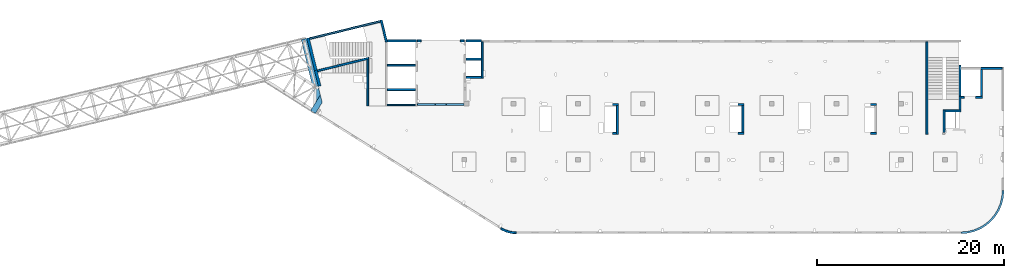
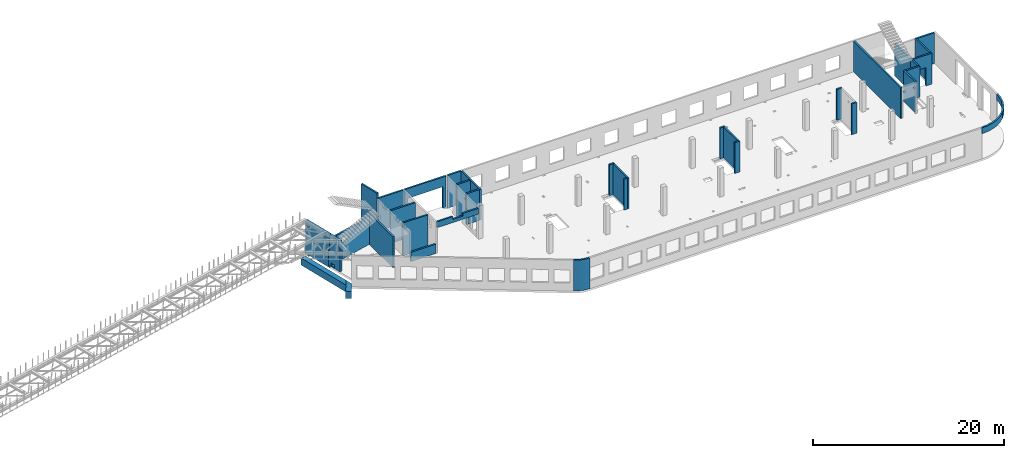
# One storey, part 15 of 67: 36 walls, 4 openings.
"""IFC4 building model written with IfcOpenShell, lengths in millimetres."""

from ifc_helpers import new_model, entity, si_unit, converted_unit, derived_unit, direction, frame, origin, place, context, subcontext, project, spatial, indexed_curve, outline, extrude, polygons, material, type_object, element, save


model = new_model("IFC4")

# Units and contexts
model_context = context("Model", 3, precision=0.01, world=origin(), true_north=direction((6.12303176911189e-17, 1.0)))
plan_context = context("Plan", 3, precision=0.01, world=origin(), true_north=direction((6.12303176911189e-17, 1.0)))
body_context = subcontext(model_context, "Body", "Model", "MODEL_VIEW")
ifc_project = project(units=[si_unit("LENGTHUNIT", "METRE", prefix="MILLI"), si_unit("AREAUNIT", "SQUARE_METRE"), si_unit("VOLUMEUNIT", "CUBIC_METRE"), converted_unit("PLANEANGLEUNIT", "DEGREE", entity("IfcRatioMeasure", 0.0174532925199433), si_unit("PLANEANGLEUNIT", "RADIAN"), dimensions=[0, 0, 0, 0, 0, 0, 0]), si_unit("MASSUNIT", "GRAM", prefix="KILO"), derived_unit("MASSDENSITYUNIT", [(si_unit("MASSUNIT", "GRAM", prefix="KILO"), 1), (si_unit("LENGTHUNIT", "METRE"), -3)]), derived_unit("MOMENTOFINERTIAUNIT", [(si_unit("LENGTHUNIT", "METRE"), 4)]), si_unit("TIMEUNIT", "SECOND"), si_unit("FREQUENCYUNIT", "HERTZ"), si_unit("THERMODYNAMICTEMPERATUREUNIT", "DEGREE_CELSIUS"), derived_unit("THERMALTRANSMITTANCEUNIT", [(si_unit("MASSUNIT", "GRAM", prefix="KILO"), 1), (si_unit("THERMODYNAMICTEMPERATUREUNIT", "KELVIN"), -1), (si_unit("TIMEUNIT", "SECOND"), -3)]), derived_unit("VOLUMETRICFLOWRATEUNIT", [(si_unit("LENGTHUNIT", "METRE"), 3), (si_unit("TIMEUNIT", "SECOND"), -1)]), derived_unit("MASSFLOWRATEUNIT", [(si_unit("MASSUNIT", "GRAM", prefix="KILO"), 1), (si_unit("TIMEUNIT", "SECOND"), -1)]), derived_unit("ROTATIONALFREQUENCYUNIT", [(si_unit("TIMEUNIT", "SECOND"), -1)]), si_unit("ELECTRICCURRENTUNIT", "AMPERE"), si_unit("ELECTRICVOLTAGEUNIT", "VOLT"), si_unit("POWERUNIT", "WATT"), si_unit("FORCEUNIT", "NEWTON", prefix="KILO"), si_unit("ILLUMINANCEUNIT", "LUX"), si_unit("LUMINOUSFLUXUNIT", "LUMEN"), si_unit("LUMINOUSINTENSITYUNIT", "CANDELA"), derived_unit("USERDEFINED", [(si_unit("MASSUNIT", "GRAM", prefix="KILO"), -1), (si_unit("LENGTHUNIT", "METRE"), -2), (si_unit("TIMEUNIT", "SECOND"), 3), (si_unit("LUMINOUSFLUXUNIT", "LUMEN"), 1)]), derived_unit("LINEARVELOCITYUNIT", [(si_unit("LENGTHUNIT", "METRE"), 1), (si_unit("TIMEUNIT", "SECOND"), -1)]), si_unit("PRESSUREUNIT", "PASCAL"), derived_unit("USERDEFINED", [(si_unit("LENGTHUNIT", "METRE"), -2), (si_unit("MASSUNIT", "GRAM", prefix="KILO"), 1), (si_unit("TIMEUNIT", "SECOND"), -2)]), derived_unit("LINEARFORCEUNIT", [(si_unit("MASSUNIT", "GRAM", prefix="KILO"), 1), (si_unit("LENGTHUNIT", "METRE"), 1), (si_unit("TIMEUNIT", "SECOND"), -2), (si_unit("LENGTHUNIT", "METRE"), -1)]), derived_unit("PLANARFORCEUNIT", [(si_unit("MASSUNIT", "GRAM", prefix="KILO"), 1), (si_unit("LENGTHUNIT", "METRE"), 1), (si_unit("TIMEUNIT", "SECOND"), -2), (si_unit("LENGTHUNIT", "METRE"), -2)])], contexts=[model_context, plan_context])

# Site, building, storey
site_placement = place(None, origin())
site = spatial("IfcSite", under=ifc_project, at=site_placement, CompositionType="ELEMENT")
building_placement = place(site_placement, origin())
building = spatial("IfcBuilding", under=site, at=building_placement, CompositionType="ELEMENT")
storey_placement = place(building_placement, frame((0.0, 0.0, 19800.0)))
storey = spatial("IfcBuildingStorey", under=building, at=storey_placement, CompositionType="ELEMENT", Elevation=19800.0)

# Walls
ifc_material = material()
wall_type_1 = type_object("IfcWallType", PredefinedType="STANDARD")
wall_1_placement = place(storey_placement, frame((45670.0002685547, 13499.9992263556, -150.0), z_axis=(0.0, 0.0, 1.0), x_axis=(0.0, -1.0, 0.0)))
element("IfcWall", 1, at=wall_1_placement, inside=storey, type_object=wall_type_1, material=ifc_material, PredefinedType="NOTDEFINED", context=body_context, shape_type="SweptSolid", body=[
    extrude(outline(indexed_curve([(2874.99985044015, 100.000000000003), (0.0, 100.000000000003), (0.0, -100.000000000003), (2874.99985044015, -100.000000000003), (2874.99985044015, 100.000000000003)], self_intersect=False)), origin(), (0.0, 0.0, 1.0), 3950.0),
])
wall_2_placement = place(storey_placement, frame((32270.0002685547, 13499.9992263557, -150.0), z_axis=(0.0, 0.0, 1.0), x_axis=(0.0, -1.0, 0.0)))
element("IfcWall", 2, at=wall_2_placement, inside=storey, type_object=wall_type_1, material=ifc_material, PredefinedType="NOTDEFINED", context=body_context, shape_type="SweptSolid", body=[
    extrude(outline(indexed_curve([(3074.99985044025, 99.9999999999989), (0.0, 99.9999999999989), (0.0, -99.9999999999989), (3074.99985044025, -99.9999999999989), (3074.99985044025, 99.9999999999989)], self_intersect=False)), origin(), (0.0, 0.0, 1.0), 3950.0),
])
wall_3_placement = place(storey_placement, frame((65330.0002685547, 20299.9998657227, -150.0), z_axis=(0.0, 0.0, 1.0), x_axis=(0.0, -1.0, 0.0)))
element("IfcWall", 3, at=wall_3_placement, inside=storey, type_object=wall_type_1, material=ifc_material, PredefinedType="NOTDEFINED", context=body_context, shape_type="SweptSolid", body=[
    extrude(outline(indexed_curve([(9875.00063936714, 100.000000000003), (0.0, 100.000000000003), (0.0, -100.000000000003), (9875.00063936714, -100.000000000003), (9875.00063936714, 100.000000000003)], self_intersect=False)), origin(), (0.0, 0.0, 1.0), 3950.0),
])
wall_4_placement = place(storey_placement, frame((67180.0002685547, 10624.9992263555, -150.0), z_axis=(0.0, 0.0, 1.0), x_axis=(0.0, 1.0, 0.0)))
element("IfcWall", 4, at=wall_4_placement, inside=storey, type_object=wall_type_1, material=ifc_material, PredefinedType="NOTDEFINED", context=body_context, shape_type="SweptSolid", body=[
    extrude(outline(indexed_curve([(2404.99999999995, 100.000000000003), (0.0, 100.000000000003), (0.0, -100.000000000003), (2404.99999999995, -100.000000000003), (2404.99999999995, 100.000000000003)], self_intersect=False)), origin(), (0.0, 0.0, 1.0), 3950.0),
])
wall_5_placement = place(storey_placement, frame((68870.0002685547, 13029.9992263555, -150.0), z_axis=(0.0, 0.0, 1.0), x_axis=(0.0, 1.0, 0.0)))
element("IfcWall", 5, at=wall_5_placement, inside=storey, type_object=wall_type_1, material=ifc_material, PredefinedType="NOTDEFINED", context=body_context, shape_type="SweptSolid", body=[
    extrude(outline(indexed_curve([(1439.99999999999, 100.000000000003), (0.0, 100.000000000003), (0.0, -100.000000000003), (1439.99999999999, -100.000000000003), (1439.99999999999, 100.000000000003)], self_intersect=False)), origin(), (0.0, 0.0, 1.0), 3950.0),
])
wall_6_placement = place(storey_placement, frame((68970.0002685547, 12929.9992263555, -150.0), z_axis=(0.0, 0.0, 1.0), x_axis=(-1.0, 0.0, 0.0)))
element("IfcWall", 6, at=wall_6_placement, inside=storey, type_object=wall_type_1, material=ifc_material, PredefinedType="NOTDEFINED", context=body_context, shape_type="SweptSolid", body=[
    extrude(outline(indexed_curve([(1689.99999999997, 100.000000000001), (-3.62972222111202e-13, 100.000000000001), (3.62972222111202e-13, -100.000000000001), (1689.99999999997, -100.000000000001), (1689.99999999997, 100.000000000001)], self_intersect=False)), origin(), (0.0, 0.0, 1.0), 3950.0),
])

# Wall, opening
wall_7_placement = place(storey_placement, frame((68970.0002685547, 14369.9992263555, -150.0)))
wall_7 = element("IfcWall", 7, at=wall_7_placement, inside=storey, type_object=wall_type_1, material=ifc_material, PredefinedType="NOTDEFINED", context=body_context, shape_type="Tessellation", body=[
    polygons([(2299.99918212888, -99.9999999999989, 3950.0), (1.01625571232879e-11, -100.000000000001, 3950.0), (1.01625571232879e-11, -100.000000000001, 0.0), (330.000000000004, -99.9999999999989, 0.0), (330.000000000004, -99.9999999999989, 2369.99999999804), (1570.0, -100.000000000001, 2369.99999999805), (1570.0, -100.000000000001, 0.0), (2299.99918212888, -99.9999999999989, 0.0), (9.57650151922299e-12, 100.000000000001, 3950.0), (2099.99918212888, 99.9999999999989, 3950.0), (2299.99918212888, 99.9999999999989, 3950.0), (2299.99918212888, 99.9999999999989, 0.0), (2099.99918212888, 99.9999999999989, 0.0), (1570.0, 99.9999999999989, 0.0), (1570.0, 99.9999999999989, 2369.99999999805), (330.000000000013, 99.9999999999989, 2369.99999999804), (330.000000000004, 100.000000000003, 0.0), (9.57650151922299e-12, 100.000000000001, 0.0)], [[[1, 2, 3, 4, 5, 6, 7, 8]], [[9, 10, 11, 12, 13, 14, 15, 16, 17, 18]], [[3, 18, 17, 4]], [[2, 1, 11, 10, 9]], [[1, 8, 12, 11]], [[15, 6, 5, 16]], [[16, 5, 4, 17]], [[6, 15, 14, 7]], [[18, 3, 2, 9]], [[12, 8, 7, 14, 13]]], closed=True),
])
opening_1_placement = place(wall_7_placement, frame((-68970.0002685547, -14369.9992263555, 150.0)))
element("IfcOpeningElement", 8, at=opening_1_placement, cuts=wall_7, PredefinedType="OPENING", context=body_context, shape_type="SweptSolid", body=[
    extrude(outline(indexed_curve([(-1184.99999999902, -619.999999999998), (1184.99999999902, -619.999999999998), (1184.99999999902, 620.000000000006), (-1184.99999999902, 620.000000000006), (-1184.99999999902, -619.999999999998)], self_intersect=False)), frame((69920.0002685547, 14169.9992263555, 1035.0), z_axis=(0.0, 1.0, 0.0), x_axis=(0.0, 0.0, -1.0)), (0.0, 0.0, 1.0), 400.000000001943),
])

# Walls
wall_8_placement = place(storey_placement, frame((73369.9994506836, 17469.9992263554, -150.0), z_axis=(0.0, 0.0, 1.0), x_axis=(-1.0, 0.0, 0.0)))
element("IfcWall", 9, at=wall_8_placement, inside=storey, type_object=wall_type_1, material=ifc_material, PredefinedType="NOTDEFINED", context=body_context, shape_type="SweptSolid", body=[
    extrude(outline(indexed_curve([(2300.00000000001, 99.9999999999992), (-2.9506601880044e-13, 99.9999999999989), (2.9506601880044e-13, -99.9999999999989), (2300.00000000001, -99.9999999999986), (2300.00000000001, 99.9999999999992)], self_intersect=False)), origin(), (0.0, 0.0, 1.0), 3950.0),
])
wall_9_placement = place(storey_placement, frame((71169.9994506836, 14469.9992263555, -150.0), z_axis=(0.0, 0.0, 1.0), x_axis=(0.0, 1.0, 0.0)))
element("IfcWall", 10, at=wall_9_placement, inside=storey, type_object=wall_type_1, material=ifc_material, PredefinedType="NOTDEFINED", context=body_context, shape_type="SweptSolid", body=[
    extrude(outline(indexed_curve([(2900.0, 100.000000000003), (0.0, 100.000000000003), (0.0, -100.000000000003), (2900.0, -100.000000000003), (2900.0, 100.000000000003)], self_intersect=False)), origin(), (0.0, 0.0, 1.0), 3950.0),
])
wall_10_placement = place(storey_placement, frame((5723.68287785373, 18543.916804035, -150.0), z_axis=(0.0, 0.0, 1.0), x_axis=(-0.971552058141474, -0.236826092990332, 0.0)))
element("IfcWall", 11, at=wall_10_placement, inside=storey, type_object=wall_type_1, material=ifc_material, PredefinedType="NOTDEFINED", context=body_context, shape_type="Tessellation", body=[
    polygons([(0.0, -100.000000000001, 0.0), (5664.5968788743, -99.9999999999946, 0.0), (5664.5968788743, -99.9999999999946, 2020.0), (3907.95430516149, -99.9999999999989, 2020.0), (0.0, -100.000000000001, 3921.35271860844), (48.7521159583292, 100.000000000001, 0.0), (48.7521159583292, 100.000000000001, 3897.63315564096), (3907.95430516149, 100.000000000001, 2020.0), (5664.5968788743, 99.9999999999989, 2020.0), (5664.5968788743, 99.9999999999989, 0.0), (254.608300734047, 100.000000000003, 0.0), (5664.5968788743, 0.0, 2020.0)], [[[1, 2, 3, 4, 5]], [[6, 7, 8, 9, 10, 11]], [[1, 5, 7, 6]], [[3, 2, 10, 9, 12]], [[2, 1, 6, 11, 10]], [[4, 3, 12, 9, 8]], [[5, 4, 8, 7]]], closed=True),
])
wall_11_placement = place(storey_placement, frame((5600.0002685547, 18435.2158250734, -150.0), z_axis=(0.0, 0.0, 1.0), x_axis=(0.0, -1.0, 0.0)))
element("IfcWall", 12, at=wall_11_placement, inside=storey, type_object=wall_type_1, material=ifc_material, PredefinedType="NOTDEFINED", context=body_context, shape_type="SweptSolid", body=[
    extrude(outline(indexed_curve([(4985.21659871757, -100.0), (4985.21659871757, 99.9999999999999), (2.01604199470658e-12, 100.0), (48.7521159583304, -99.9999999999999), (4985.21659871757, -100.0)], self_intersect=False)), origin(), (0.0, 0.0, 1.0), 3950.0),
])
wall_12_placement = place(storey_placement, frame((7033.44218130896, 22609.751914045, -150.0), z_axis=(0.0, 0.0, 1.0), x_axis=(0.236826092990328, -0.971552058141475, 0.0)))
element("IfcWall", 13, at=wall_12_placement, inside=storey, type_object=wall_type_1, material=ifc_material, PredefinedType="NOTDEFINED", context=body_context, shape_type="SweptSolid", body=[
    extrude(outline(indexed_curve([(2380.28371765147, -99.9999999999991), (2404.30804833169, 99.9999999999997), (2195.90383852408, 99.9999999999997), (1.1420864254319e-13, 99.9999999999997), (-1.1420864254319e-13, -99.9999999999997), (200.000000000008, -99.9999999999999), (2380.28371765147, -99.9999999999991)], self_intersect=False)), origin(), (0.0, 0.0, 1.0), 4700.0),
])
wall_13_placement = place(storey_placement, frame((7700.00026855469, 15199.9998657227, -400.0)))
element("IfcWall", 14, at=wall_13_placement, inside=storey, type_object=wall_type_1, material=ifc_material, PredefinedType="NOTDEFINED", context=body_context, shape_type="SweptSolid", body=[
    extrude(outline(indexed_curve([(3000.0, 100.000000000001), (-2.88764567812907e-13, 100.000000000001), (2.88764567812907e-13, -100.000000000001), (3000.0, -100.000000000001), (3000.0, 100.000000000001)], self_intersect=False)), origin(), (0.0, 0.0, 1.0), 4200.0),
])
wall_14_placement = place(storey_placement, frame((7700.0002685547, 17799.9998657227, -400.0)))
element("IfcWall", 15, at=wall_14_placement, inside=storey, type_object=wall_type_1, material=ifc_material, PredefinedType="NOTDEFINED", context=body_context, shape_type="SweptSolid", body=[
    extrude(outline(indexed_curve([(3000.0, 99.9999999999989), (-2.88764567812902e-13, 99.9999999999989), (2.88764567812902e-13, -99.9999999999989), (3000.0, -99.9999999999989), (3000.0, 99.9999999999989)], self_intersect=False)), origin(), (0.0, 0.0, 1.0), 4200.0),
])
wall_15_placement = place(storey_placement, frame((17825.0002685547, 20299.9998657227, -150.0), z_axis=(0.0, 0.0, 1.0), x_axis=(0.0, -1.0, 0.0)))
element("IfcWall", 16, at=wall_15_placement, inside=storey, type_object=wall_type_1, material=ifc_material, PredefinedType="NOTDEFINED", context=body_context, shape_type="SweptSolid", body=[
    extrude(outline(indexed_curve([(3900.00063936684, 99.9999999999987), (6.05595613557109e-14, 99.9999999999989), (-6.05595613557109e-14, -99.9999999999989), (3900.00063936684, -99.9999999999991), (3900.00063936684, 99.9999999999987)], self_intersect=False)), origin(), (0.0, 0.0, 1.0), 3950.0),
])
wall_16_placement = place(storey_placement, frame((17725.0002685547, 18449.9998657227, -400.0), z_axis=(0.0, 0.0, 1.0), x_axis=(-1.0, 0.0, 0.0)))
element("IfcWall", 17, at=wall_16_placement, inside=storey, type_object=wall_type_1, material=ifc_material, PredefinedType="NOTDEFINED", context=body_context, shape_type="SweptSolid", body=[
    extrude(outline(indexed_curve([(1625.0, 99.9999999999989), (-2.66551908750371e-13, 99.9999999999989), (2.66551908750371e-13, -99.9999999999989), (1625.0, -99.9999999999989), (1625.0, 99.9999999999989)], self_intersect=False)), origin(), (0.0, 0.0, 1.0), 4200.0),
])
wall_17_placement = place(storey_placement, frame((16100.0002685547, 16499.9992263558, -150.0)))
element("IfcWall", 18, at=wall_17_placement, inside=storey, type_object=wall_type_1, material=ifc_material, PredefinedType="NOTDEFINED", context=body_context, shape_type="SweptSolid", body=[
    extrude(outline(indexed_curve([(1625.0, 99.9999999999989), (-2.66551908750371e-13, 99.9999999999989), (2.66551908750371e-13, -99.9999999999989), (1625.0, -99.9999999999989), (1625.0, 99.9999999999989)], self_intersect=False)), origin(), (0.0, 0.0, 1.0), 3950.0),
])
wall_18_placement = place(storey_placement, frame((19822.2736066773, 371.03572064539, -150.0)))
element("IfcWall", 19, at=wall_18_placement, inside=storey, type_object=wall_type_1, material=ifc_material, PredefinedType="NOTDEFINED", context=body_context, shape_type="SweptSolid", body=[
    extrude(outline(indexed_curve([(1642.72666187733, -371.036494289582), (1475.26477394354, -366.358933709024), (1308.32509476025, -352.340838349344), (1142.4282046359, -329.025921870721), (978.091432072955, -296.486888895996), (815.827240544267, -254.825208290483), (656.141630440456, -204.170796744129), (499.532561171588, -144.68161364272), (346.48839834364, -76.5431684914861), (197.486390852038, 0.0320575728661979), (52.9911826412237, 84.8052743777455), (-52.9911826412064, -84.8052743777552), (101.137039450331, -175.230038969628), (260.072514108048, -256.91028010494), (423.319621124515, -329.591288266255), (590.36929501131, -393.046416907758), (760.700612455376, -447.077789223871), (933.78241675264, -491.516915203086), (1109.07497415312, -526.225217042794), (1286.03165695242, -551.094461286659), (1464.10064808126, -566.047096336985), (1642.72666187731, -571.036494289582), (1642.72666187733, -371.036494289582)], self_intersect=False)), origin(), (0.0, 0.0, 1.0), 3950.0),
])
wall_19_placement = place(storey_placement, frame((73469.9994506836, 4399.99922635544, 3050.0)))
element("IfcWall", 20, at=wall_19_placement, inside=storey, type_object=wall_type_1, material=ifc_material, PredefinedType="NOTDEFINED", context=body_context, shape_type="SweptSolid", body=[
    extrude(outline(indexed_curve([(-4499.99918212898, -4599.99918212887), (-3780.40077088714, -4543.36555893587), (-3078.52126074028, -4374.85919711607), (-2411.64325463275, -4098.62928253802), (-1796.18750231614, -3721.47751245316), (-1247.30856699303, -3252.69061513595), (-778.521669675789, -2703.81167981284), (-401.369899590915, -2088.35592749624), (-125.139985012846, -1421.47792138872), (43.366376806984, -719.59841124187), (100.000000000003, -3.19445803143026e-11), (-99.9999999999946, 0.0), (-154.171291312042, -688.311518233791), (-315.351288271866, -1359.67452251371), (-579.571204428578, -1997.5578275483), (-940.325068550761, -2586.25462935432), (-1388.72992323031, -3111.26925889861), (-1913.74455277461, -3559.67411357815), (-2502.44135458064, -3920.42797770033), (-3140.32465961524, -4184.64789385703), (-3811.68766389516, -4345.82789081684), (-4499.99918212895, -4399.99918212887), (-4499.99918212898, -4599.99918212887)], self_intersect=False)), origin(), (0.0, 0.0, 1.0), 750.000000000003),
])
wall_20_placement = place(storey_placement, frame((32170.0002685547, 10524.9993759155, -150.0), z_axis=(0.0, 0.0, 1.0), x_axis=(-1.0, 0.0, 0.0)))
element("IfcWall", 21, at=wall_20_placement, inside=storey, type_object=wall_type_1, material=ifc_material, PredefinedType="NOTDEFINED", context=body_context, shape_type="SweptSolid", body=[
    extrude(outline(indexed_curve([(400.0, 99.9999999999981), (-3.43767342634407e-13, 99.9999999999989), (3.43767342634407e-13, -99.9999999999989), (400.0, -99.9999999999997), (400.0, 99.9999999999981)], self_intersect=False)), origin(), (0.0, 0.0, 1.0), 3950.0),
])
wall_21_placement = place(storey_placement, frame((32370.0002685547, 13599.9992263557, -150.0), z_axis=(0.0, 0.0, 1.0), x_axis=(-1.0, 0.0, 0.0)))
element("IfcWall", 22, at=wall_21_placement, inside=storey, type_object=wall_type_1, material=ifc_material, PredefinedType="NOTDEFINED", context=body_context, shape_type="SweptSolid", body=[
    extrude(outline(indexed_curve([(600.000000000002, 99.9999999999979), (-5.58957591434401e-13, 99.9999999999989), (5.58957591434401e-13, -99.9999999999989), (600.000000000003, -99.9999999999999), (600.000000000002, 99.9999999999979)], self_intersect=False)), origin(), (0.0, 0.0, 1.0), 3950.0),
])
wall_22_placement = place(storey_placement, frame((45770.0002685547, 13599.9992263556, -150.0), z_axis=(0.0, 0.0, 1.0), x_axis=(-1.0, 0.0, 0.0)))
element("IfcWall", 23, at=wall_22_placement, inside=storey, type_object=wall_type_1, material=ifc_material, PredefinedType="NOTDEFINED", context=body_context, shape_type="SweptSolid", body=[
    extrude(outline(indexed_curve([(599.999999999993, 99.9999999999978), (-5.41433564649196e-13, 99.9999999999989), (5.41433564649196e-13, -99.9999999999989), (599.999999999994, -100.0), (599.999999999993, 99.9999999999978)], self_intersect=False)), origin(), (0.0, 0.0, 1.0), 3950.0),
])
wall_23_placement = place(storey_placement, frame((45770.0002685547, 10524.9993759154, -150.0), z_axis=(0.0, 0.0, 1.0), x_axis=(-1.0, 0.0, 0.0)))
element("IfcWall", 24, at=wall_23_placement, inside=storey, type_object=wall_type_1, material=ifc_material, PredefinedType="NOTDEFINED", context=body_context, shape_type="SweptSolid", body=[
    extrude(outline(indexed_curve([(600.000000000002, 99.9999999999978), (-5.39089922916519e-13, 99.9999999999989), (5.39089922916519e-13, -99.9999999999989), (600.000000000003, -100.0), (600.000000000002, 99.9999999999978)], self_intersect=False)), origin(), (0.0, 0.0, 1.0), 3950.0),
])
wall_24_placement = place(storey_placement, frame((59930.0002685547, 13599.9992263555, -150.0), z_axis=(0.0, 0.0, 1.0), x_axis=(-1.0, 0.0, 0.0)))
element("IfcWall", 25, at=wall_24_placement, inside=storey, type_object=wall_type_1, material=ifc_material, PredefinedType="NOTDEFINED", context=body_context, shape_type="SweptSolid", body=[
    extrude(outline(indexed_curve([(600.00000000001, 99.9999999999978), (-5.41433564649173e-13, 99.9999999999989), (5.41433564649173e-13, -99.9999999999989), (600.000000000011, -100.0), (600.00000000001, 99.9999999999978)], self_intersect=False)), origin(), (0.0, 0.0, 1.0), 3950.0),
])
wall_25_placement = place(storey_placement, frame((59930.0002685547, 10524.9992263555, -150.0), z_axis=(0.0, 0.0, 1.0), x_axis=(-1.0, 0.0, 0.0)))
element("IfcWall", 26, at=wall_25_placement, inside=storey, type_object=wall_type_1, material=ifc_material, PredefinedType="NOTDEFINED", context=body_context, shape_type="SweptSolid", body=[
    extrude(outline(indexed_curve([(599.999999999994, 99.9999999999989), (0.0, 99.9999999999989), (0.0, -99.9999999999989), (599.999999999994, -99.9999999999989), (599.999999999994, 99.9999999999989)], self_intersect=False)), origin(), (0.0, 0.0, 1.0), 3950.0),
])

# Wall, opening
wall_26_placement = place(storey_placement, frame((10900.0002685547, 13599.9992263559, 3050.0)))
wall_26 = element("IfcWall", 27, at=wall_26_placement, inside=storey, type_object=wall_type_1, material=ifc_material, PredefinedType="NOTDEFINED", context=body_context, shape_type="Tessellation", body=[
    polygons([(2.16569675683432e-13, -100.000000000001, 0.0), (4999.99925537109, -100.000000000001, 0.0), (4999.99925537109, -100.000000000001, 749.999999999998), (3100.0, -99.9999999999989, 749.999999999998), (3100.0, -99.9999999999989, 400.0), (1900.0, -100.000000000001, 400.0), (1900.0, -100.000000000001, 749.999999999998), (2.16569675683432e-13, -100.000000000001, 749.999999999998), (1.77589825156368e-12, 99.9999999999989, 0.0), (-3.89836007033108e-13, 99.9999999999989, 749.999999999998), (1900.0, 99.9999999999989, 749.999999999998), (1900.0, 99.9999999999989, 400.0), (3100.0, 100.000000000001, 400.0), (3100.0, 100.000000000001, 749.999999999998), (4999.99925537109, 99.9999999999989, 749.999999999998), (4999.99925537109, 99.9999999999989, 0.0)], [[[1, 2, 3, 4, 5, 6, 7, 8]], [[9, 10, 11, 12, 13, 14, 15, 16]], [[1, 8, 10, 9]], [[2, 1, 9, 16]], [[3, 2, 16, 15]], [[4, 3, 15, 14]], [[5, 4, 14, 13]], [[6, 5, 13, 12]], [[7, 6, 12, 11]], [[8, 7, 11, 10]]], closed=True),
])
opening_2_placement = place(wall_26_placement, origin())
element("IfcOpeningElement", 28, at=opening_2_placement, cuts=wall_26, PredefinedType="OPENING", context=body_context, shape_type="SweptSolid", body=[
    extrude(outline(indexed_curve([(-599.999999999998, -174.999999999999), (600.000000000002, -174.999999999999), (600.000000000002, 174.999999999999), (-599.999999999998, 174.999999999999), (-599.999999999998, -174.999999999999)], self_intersect=False)), frame((2500.0, 100.0, 575.0), z_axis=(0.0, -1.0, 0.0), x_axis=(-1.0, 0.0, 0.0)), (0.0, 0.0, 1.0), 200.0),
])

# Walls
wall_27_placement = place(storey_placement, frame((-618.12876397421, 20641.672451718, -900.0), z_axis=(0.0, 0.0, 1.0), x_axis=(0.971552058141473, 0.236826092990338, 0.0)))
element("IfcWall", 29, at=wall_27_placement, inside=storey, type_object=wall_type_1, material=ifc_material, PredefinedType="NOTDEFINED", context=body_context, shape_type="SweptSolid", body=[
    extrude(outline(indexed_curve([(7799.9920696628, 100.0), (-5.4989346409684e-14, 100.0), (5.4989346409684e-14, -100.0), (7799.9920696628, -100.0), (7799.9920696628, 100.0)], self_intersect=False)), origin(), (0.0, 0.0, 1.0), 750.000000000003),
])
wall_28_placement = place(storey_placement, frame((68870.0002685547, 14269.9992263555, -400.0), z_axis=(0.0, 0.0, 1.0), x_axis=(0.0, 1.0, 0.0)))
element("IfcWall", 30, at=wall_28_placement, inside=storey, type_object=wall_type_1, material=ifc_material, PredefinedType="NOTDEFINED", context=body_context, shape_type="SweptSolid", body=[
    extrude(outline(indexed_curve([(3510.0, -99.9999999999946), (3510.0, 100.000000000003), (200.0, 100.000000000003), (0.0, 100.000000000003), (0.0, -99.9999999999946), (200.0, -99.9999999999946), (3100.0, -99.9999999999946), (3300.0, -99.9999999999946), (3510.0, -99.9999999999946)], self_intersect=False)), origin(), (0.0, 0.0, 1.0), 4200.0),
])
wall_29_placement = place(storey_placement, frame((17725.0002685547, 20399.9998657227, -400.0), z_axis=(0.0, 0.0, 1.0), x_axis=(-1.0, 0.0, 0.0)))
element("IfcWall", 31, at=wall_29_placement, inside=storey, type_object=wall_type_1, material=ifc_material, PredefinedType="NOTDEFINED", context=body_context, shape_type="SweptSolid", body=[
    extrude(outline(indexed_curve([(1624.99999999999, 99.9999999999988), (8.49307538770806e-15, 99.9999999999989), (-8.49307538770806e-15, -99.9999999999989), (1624.99999999999, -99.9999999999991), (1624.99999999999, 99.9999999999988)], self_intersect=False)), origin(), (0.0, 0.0, 1.0), 4200.0),
])

# Wall, opening
wall_30_placement = place(storey_placement, frame((15900.0002685547, 20399.9998657227, -150.0), z_axis=(0.0, 0.0, 1.0), x_axis=(-1.0, 0.0, 0.0)))
wall_30 = element("IfcWall", 32, at=wall_30_placement, inside=storey, type_object=wall_type_1, material=ifc_material, PredefinedType="NOTDEFINED", context=body_context, shape_type="Tessellation", body=[
    polygons([(5000.00000000001, -99.9999999999989, 3950.0), (4.24653815520889e-13, -99.9999999999989, 3950.0), (4.24653815520889e-13, -99.9999999999989, 0.0), (400.000000000013, -99.9999999999989, 0.0), (400.000000000013, -99.9999999999989, 2699.99999999804), (4600.00000000001, -99.9999999999989, 2699.99999999804), (4600.00000000001, -99.9999999999989, 0.0), (5000.00000000001, -99.9999999999989, 0.0), (4.41639966296306e-13, 99.9999999999989, 3950.0), (5000.00000000001, 99.9999999999989, 3950.0), (5000.00000000001, 99.9999999999989, 0.0), (4600.00000000001, 99.9999999999989, 0.0), (4600.00000000001, 99.9999999999989, 2699.99999999804), (400.000000000013, 99.9999999999989, 2699.99999999804), (400.000000000013, 99.9999999999989, 0.0), (4.41639966296306e-13, 99.9999999999989, 0.0)], [[[1, 2, 3, 4, 5, 6, 7, 8]], [[9, 10, 11, 12, 13, 14, 15, 16]], [[3, 16, 15, 4]], [[2, 1, 10, 9]], [[13, 6, 5, 14]], [[14, 5, 4, 15]], [[6, 13, 12, 7]], [[3, 2, 9, 16]], [[8, 11, 10, 1]], [[11, 8, 7, 12]]], closed=True),
])
opening_3_placement = place(wall_30_placement, frame((15900.0002685547, 20399.9998657227, 150.0), z_axis=(0.0, 0.0, 1.0), x_axis=(-1.0, 0.0, 0.0)))
element("IfcOpeningElement", 33, at=opening_3_placement, cuts=wall_30, PredefinedType="OPENING", context=body_context, shape_type="SweptSolid", body=[
    extrude(outline(indexed_curve([(-1349.99999999902, -2100.0), (1349.99999999902, -2100.0), (1349.99999999902, 2100.0), (-1349.99999999902, 2100.0), (-1349.99999999902, -2100.0)], self_intersect=False)), frame((13400.0002685547, 20599.9998657227, 1200.0), z_axis=(0.0, -1.0, 0.0), x_axis=(0.0, 0.0, -1.0)), (0.0, 0.0, 1.0), 400.000000001945),
])

# Walls
wall_31_placement = place(storey_placement, frame((10800.0002685547, 20399.9998657227, -400.0), z_axis=(0.0, 0.0, 1.0), x_axis=(-1.0, 0.0, 0.0)))
element("IfcWall", 34, at=wall_31_placement, inside=storey, type_object=wall_type_1, material=ifc_material, PredefinedType="NOTDEFINED", context=body_context, shape_type="SweptSolid", body=[
    extrude(outline(indexed_curve([(3149.35561234222, -99.9999999999992), (3100.6034963839, 99.9999999999987), (8.49307538770806e-15, 99.9999999999989), (-8.49307538770806e-15, -99.9999999999989), (99.9999999999946, -99.9999999999989), (3149.35561234222, -99.9999999999992)], self_intersect=False)), origin(), (0.0, 0.0, 1.0), 4200.0),
])
wall_32_placement = place(storey_placement, frame((7700.00026855469, 13549.9992263559, -150.0)))
element("IfcWall", 35, at=wall_32_placement, inside=storey, type_object=wall_type_1, material=ifc_material, PredefinedType="NOTDEFINED", context=body_context, shape_type="SweptSolid", body=[
    extrude(outline(indexed_curve([(3000.0, 99.9999999999989), (-2.88764567812901e-13, 99.9999999999989), (2.88764567812901e-13, -99.9999999999989), (3000.0, -99.9999999999989), (3000.0, 99.9999999999989)], self_intersect=False)), origin(), (0.0, 0.0, 1.0), 1200.0),
])

# Wall, opening
wall_type_2 = type_object("IfcWallType", PredefinedType="STANDARD")
wall_33_placement = place(storey_placement, frame((462.892797448569, 15573.5285333679, -150.0), z_axis=(0.0, 0.0, 1.0), x_axis=(-0.236826092990339, 0.971552058141473, 0.0)))
wall_33 = element("IfcWall", 36, at=wall_33_placement, inside=storey, type_object=wall_type_2, material=ifc_material, PredefinedType="NOTDEFINED", context=body_context, shape_type="Tessellation", body=[
    polygons([(0.0, -150.0, 0.0), (1539.99447706125, -150.0, 0.0), (1739.99447706125, -149.999999999999, 0.0), (1739.99447706125, -150.0, 49.9999999999973), (1739.99447706125, -149.999999999999, 2020.0), (1639.99447706125, -150.0, 2020.0), (1639.99447706125, -150.0, 3950.0), (0.0, -150.0, 3950.0), (879.994477076674, -149.999999999999, 449.999999999997), (1379.99447707667, -150.0, 449.999999999997), (1379.99447707667, -150.0, 150.000000000009), (879.994477076674, -149.999999999999, 150.000000000009), (-2.16573425859679e-12, 150.000000000001, 0.0), (-2.16573425859679e-12, 150.000000000001, 3950.0), (1463.63192277804, 150.000000000001, 3950.0), (1639.99447706125, 150.000000000001, 3950.0), (1639.99447706125, 150.000000000001, 2020.0), (1739.99447706126, 150.000000000001, 2020.0), (1739.99447706126, 150.000000000001, 0.0), (1539.97976766027, 150.0, 0.0), (1379.99447707668, 150.000000000321, 449.999999999997), (879.994477076672, 150.000000000321, 449.999999999997), (879.994477076672, 150.000000000321, 150.000000000009), (1379.99447707668, 150.000000000321, 150.000000000009)], [[[1, 2, 3, 4, 5, 6, 7, 8], [9, 10, 11, 12]], [[13, 14, 15, 16, 17, 18, 19, 20], [21, 22, 23, 24]], [[3, 2, 1, 13, 20, 19]], [[8, 7, 16, 15, 14]], [[1, 8, 14, 13]], [[22, 21, 10, 9]], [[22, 9, 12, 23]], [[23, 12, 11, 24]], [[10, 21, 24, 11]], [[7, 6, 17, 16]], [[17, 6, 5, 18]], [[3, 19, 18, 5, 4]]], closed=True),
])
opening_4_placement = place(wall_33_placement, frame((-15020.8686064254, 4137.94236669111, 150.0), z_axis=(0.0, 0.0, 1.0), x_axis=(-0.236826092990339, -0.971552058141473, 0.0)))
element("IfcOpeningElement", 37, at=opening_4_placement, cuts=wall_33, PredefinedType="OPENING", context=body_context, shape_type="SweptSolid", body=[
    extrude(outline(indexed_curve([(-149.999999999992, -250.0), (149.999999999992, -250.0), (149.999999999992, 250.0), (-149.999999999992, 250.0), (-149.999999999992, -250.0)], self_intersect=False)), frame((341.013429063059, 16706.9009072088, 150.0), z_axis=(-0.971552058141473, -0.236826092990339, 0.0), x_axis=(0.0, 0.0, -1.0)), (0.0, 0.0, 1.0), 300.000000000962),
])

# Walls
wall_34_placement = place(storey_placement, frame((98.1854057894208, 17069.6990461345, -400.0), z_axis=(0.0, 0.0, 1.0), x_axis=(-0.236826092990339, 0.971552058141473, 0.0)))
element("IfcWall", 38, at=wall_34_placement, inside=storey, type_object=wall_type_2, material=ifc_material, PredefinedType="NOTDEFINED", context=body_context, shape_type="SweptSolid", body=[
    extrude(outline(indexed_curve([(-1.69197988952874e-13, 150.0), (2.03037586743449e-13, -150.0), (3539.99999999998, -150.0), (3739.99999999999, -150.0), (3739.99999999999, 150.0), (-1.69197988952874e-13, 150.0)], self_intersect=False)), origin(), (0.0, 0.0, 1.0), 4200.0),
])
wall_type_3 = type_object("IfcWallType", PredefinedType="STANDARD")
wall_35_placement = place(storey_placement, frame((-254.556264120304, 12798.4413392102, -1650.0), z_axis=(0.0, 0.0, 1.0), x_axis=(0.529911826412025, 0.848052743777574, 0.0)))
element("IfcWall", 39, at=wall_35_placement, inside=storey, type_object=wall_type_3, material=ifc_material, PredefinedType="NOTDEFINED", context=body_context, shape_type="SweptSolid", body=[
    extrude(outline(indexed_curve([(1389.90316371841, -299.999999999999), (1975.44344544941, 300.0), (1137.07752204268, 300.0), (4.22994972382185e-13, 300.000000000001), (1.11670672708897e-12, -299.999999999999), (1389.90316371841, -299.999999999999)], self_intersect=False)), origin(), (0.0, 0.0, 1.0), 900.000000000003),
])
wall_36_placement = place(storey_placement, frame((385.044356666562, 13992.764427487, -1650.0), z_axis=(0.0, 0.0, 1.0), x_axis=(-0.236826092990339, 0.971552058141473, 0.0)))
element("IfcWall", 40, at=wall_36_placement, inside=storey, type_object=wall_type_3, material=ifc_material, PredefinedType="NOTDEFINED", context=body_context, shape_type="SweptSolid", body=[
    extrude(outline(indexed_curve([(6797.33784608927, -300.0), (6797.33784608927, 300.0), (-3.13016279562817e-13, 300.0), (585.540281731007, -300.0), (6797.33784608927, -300.0)], self_intersect=False)), origin(), (0.0, 0.0, 1.0), 900.000000000003),
])

save(model, "model.ifc")
